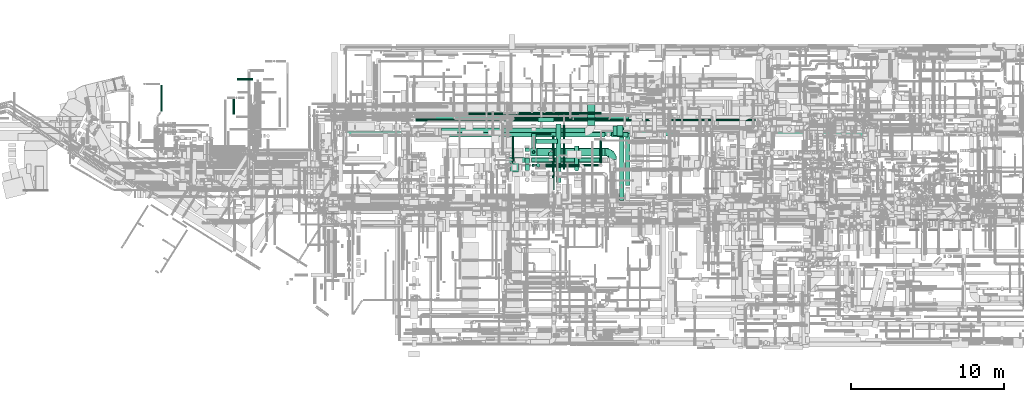
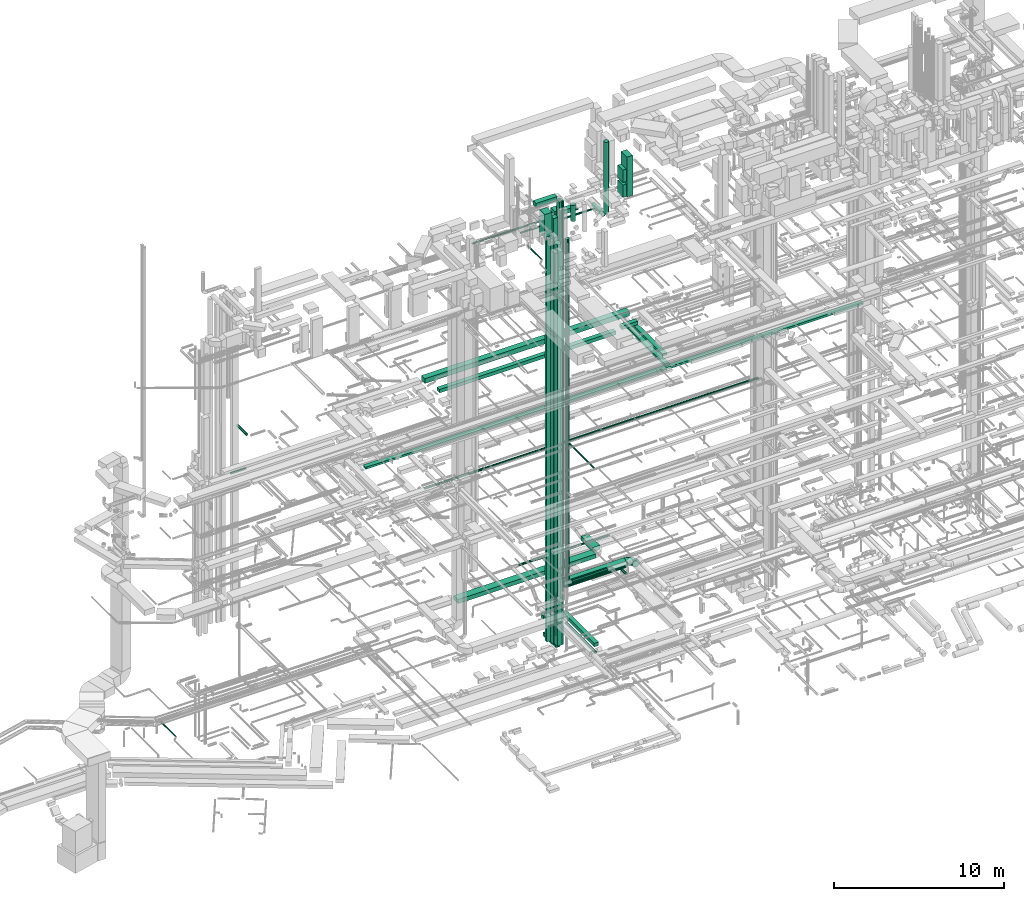
# One storey, part 35 of 337: 46 flow segments, 1 flow fitting.
"""IFC2X3 building model written with IfcOpenShell, lengths in millimetres."""

import ifcopenshell
import ifcopenshell.guid

model = None  # the IFC model being written
_history = None  # IfcOwnerHistory: only IFC2X3 demands one
_inside = {}  # id of a spatial element -> (the spatial element, [elements in it])
_under = {}  # id of a project, library or spatial element -> (it, [spatial elements below it])
_declared = {}  # id of a project -> (the project, [libraries it declares])
_typed = {}  # id of a type object -> (the type object, [elements of that type])
_made_of = {}  # id of a material, layer set ... -> (it, [elements and type objects made of it])


def new_model(schema):
    """Start an empty IFC model of exactly this schema.

    Asked for "IFC4X3", IfcOpenShell would pick the latest addendum, in which some entities
    have other attributes; the version numbers below select the first issue.
    IFC2X3 requires an IfcOwnerHistory on every rooted entity: one is made here for all.
    """
    global model, _history
    if schema == "IFC4X3":
        model = ifcopenshell.file(schema_version=(4, 3, 0, 0))
    else:
        model = ifcopenshell.file(schema=schema)
    _inside.clear()
    _under.clear()
    _declared.clear()
    _typed.clear()
    _made_of.clear()
    _history = None
    if model.schema == "IFC2X3":
        org = make("IfcOrganization", Name="unknown")
        user = make(
            "IfcPersonAndOrganization",
            ThePerson=make("IfcPerson", FamilyName="unknown"),
            TheOrganization=org,
        )
        app = make(
            "IfcApplication",
            ApplicationDeveloper=org,
            Version="unknown",
            ApplicationFullName="unknown",
            ApplicationIdentifier="unknown",
        )
        _history = make(
            "IfcOwnerHistory",
            OwningUser=user,
            OwningApplication=app,
            ChangeAction="ADDED",
            CreationDate=0,
        )
    return model


def make(cls, **values):
    """One entity of the class cls with the attributes given. An attribute that is None is left unset."""
    return model.create_entity(
        cls, **{name: value for name, value in values.items() if value is not None}
    )


def entity(cls, *values):
    """Any entity or typed value of the class cls, its attributes in the order of the schema. None: left unset."""
    e = model.create_entity(cls)
    for i, value in enumerate(values):
        if value is not None:
            e[i] = value
    return e


def rooted(cls, **values):
    """An entity with a GlobalId (a new one), such as an element, a storey or a relation."""
    return make(cls, GlobalId=ifcopenshell.guid.new(), OwnerHistory=_history, **values)


def si_unit(unit_type, name, prefix=None):
    """IfcSIUnit, for example si_unit("LENGTHUNIT", "METRE", prefix="MILLI")."""
    return make("IfcSIUnit", UnitType=unit_type, Prefix=prefix, Name=name)


def converted_unit(unit_type, name, factor, base, dimensions=None, offset=None):
    """IfcConversionBasedUnit, such as the inch: factor (a typed value) times the base unit."""
    return make(
        "IfcConversionBasedUnit"
        if offset is None
        else "IfcConversionBasedUnitWithOffset",
        ConversionOffset=offset,
        Dimensions=None
        if dimensions is None
        else entity("IfcDimensionalExponents", *dimensions),
        UnitType=unit_type,
        Name=name,
        ConversionFactor=make(
            "IfcMeasureWithUnit", ValueComponent=factor, UnitComponent=base
        ),
    )


def derived_unit(unit_type, elements):
    """IfcDerivedUnit: a product of units, each with its exponent."""
    return make(
        "IfcDerivedUnit",
        Elements=[
            make("IfcDerivedUnitElement", Unit=unit, Exponent=power)
            for unit, power in elements
        ],
        UnitType=unit_type,
    )


def assignment(units):
    """IfcUnitAssignment: the units of a project."""
    return None if units is None else make("IfcUnitAssignment", Units=units)


def point(xyz):
    """IfcCartesianPoint."""
    return None if xyz is None else make("IfcCartesianPoint", Coordinates=xyz)


def direction(xyz):
    """IfcDirection."""
    return None if xyz is None else make("IfcDirection", DirectionRatios=xyz)


def frame(location, z_axis=None, x_axis=None):
    """IfcAxis2Placement3D, a coordinate frame: its origin and axes. An axis left out is left unset."""
    return make(
        "IfcAxis2Placement3D",
        Location=point(location),
        Axis=direction(z_axis),
        RefDirection=direction(x_axis),
    )


def frame_2d(location, x_axis=None):
    """IfcAxis2Placement2D, a coordinate frame in the plane: its origin and x axis."""
    return make(
        "IfcAxis2Placement2D", Location=point(location), RefDirection=direction(x_axis)
    )


def origin():
    """The frame at (0, 0, 0) with its axes left unset."""
    return frame((0.0, 0.0, 0.0))


def origin_2d_with_axis():
    """The frame at (0, 0) in the plane with the x axis (1, 0) written out."""
    return frame_2d((0.0, 0.0), x_axis=(1.0, 0.0))


def place(relative_to, where):
    """IfcLocalPlacement: puts the frame where relative to a parent placement (None: the world)."""
    return make(
        "IfcLocalPlacement", PlacementRelTo=relative_to, RelativePlacement=where
    )


def context(
    kind, dimensions, precision=None, world=None, true_north=None, identifier=None
):
    """IfcGeometricRepresentationContext, for example the 3D "Model" context."""
    return make(
        "IfcGeometricRepresentationContext",
        ContextIdentifier=identifier,
        ContextType=kind,
        CoordinateSpaceDimension=dimensions,
        Precision=precision,
        WorldCoordinateSystem=world,
        TrueNorth=true_north,
    )


def subcontext(parent, identifier, kind, view, scale=None):
    """IfcGeometricRepresentationSubContext, for example "Body" below "Model"."""
    return make(
        "IfcGeometricRepresentationSubContext",
        ContextIdentifier=identifier,
        ContextType=kind,
        ParentContext=parent,
        TargetScale=scale,
        TargetView=view,
    )


def project(units=None, contexts=None):
    """IfcProject with its units and contexts."""
    return rooted(
        "IfcProject",
        Name="project",
        RepresentationContexts=contexts,
        UnitsInContext=assignment(units),
    )


def spatial(cls, under=None, at=None, **own):
    """A site, building, storey or space (cls), placed at a placement, below another one or the project."""
    s = rooted(cls, ObjectPlacement=at, **own)
    if under is not None:
        _under.setdefault(under.id(), (under, []))[1].append(s)
    return s


def profile(cls, at=None, kind="AREA", **sizes):
    """A parametric profile (cls). Its sizes go by their IFC names, for example OverallWidth=200.0."""
    return make(cls, ProfileType=kind, Position=at, **sizes)


def rectangle(**sizes):
    """IfcRectangleProfileDef."""
    return profile("IfcRectangleProfileDef", **sizes)


def circle(**sizes):
    """IfcCircleProfileDef."""
    return profile("IfcCircleProfileDef", **sizes)


def extrude(swept, where, along, depth):
    """IfcExtrudedAreaSolid: the profile swept, set in the frame where, extruded along a direction by depth."""
    return make(
        "IfcExtrudedAreaSolid",
        SweptArea=swept,
        Position=where,
        ExtrudedDirection=direction(along),
        Depth=depth,
    )


def faces_of(points, faces, orient=None, outer=None):
    """IfcFace entities. A face is a list of loops; a loop is a list of indices into points, from 0.

    orient and outer hold one flag for each loop. By default every Orientation is true, the
    first loop of a face is its IfcFaceOuterBound and the others are IfcFaceBound.
    """
    made = []
    for i, loops in enumerate(faces):
        bounds = []
        for j, loop in enumerate(loops):
            is_outer = j == 0 if outer is None else outer[i][j]
            bounds.append(
                make(
                    "IfcFaceOuterBound" if is_outer else "IfcFaceBound",
                    Bound=make("IfcPolyLoop", Polygon=[points[k] for k in loop]),
                    Orientation=True if orient is None else orient[i][j],
                )
            )
        made.append(make("IfcFace", Bounds=bounds))
    return made


def faceted_brep(points, faces, orient=None, outer=None, voids=None):
    """IfcFacetedBrep: a solid bounded by flat faces; with voids (closed shells), ...WithVoids."""
    shared = [point(p) for p in points]
    hull = make("IfcClosedShell", CfsFaces=faces_of(shared, faces, orient, outer))
    if voids is None:
        return make("IfcFacetedBrep", Outer=hull)
    return make(
        "IfcFacetedBrepWithVoids",
        Outer=hull,
        Voids=[
            make(cls, CfsFaces=faces_of(shared, fs, o, b)) for cls, fs, o, b in voids
        ],
    )


def shape(context_of_items, identifier, shape_type, items):
    """IfcShapeRepresentation: the items that make up one representation, for example the "Body"."""
    return make(
        "IfcShapeRepresentation",
        ContextOfItems=context_of_items,
        RepresentationIdentifier=identifier,
        RepresentationType=shape_type,
        Items=items,
    )


def source(mapping_origin, context_of_items, identifier, shape_type, items):
    """IfcRepresentationMap: a shape defined once, which mapped items show again and again."""
    return make(
        "IfcRepresentationMap",
        MappingOrigin=mapping_origin,
        MappedRepresentation=shape(context_of_items, identifier, shape_type, items),
    )


def transform(
    local_origin,
    x_axis=None,
    y_axis=None,
    z_axis=None,
    scale=None,
    scale2=None,
    scale3=None,
    uniform=True,
):
    """IfcCartesianTransformationOperator3D, or its non-uniform kind. x_axis, y_axis, z_axis: its Axis1, 2, 3."""
    if uniform:
        return make(
            "IfcCartesianTransformationOperator3D",
            Axis1=direction(x_axis),
            Axis2=direction(y_axis),
            LocalOrigin=point(local_origin),
            Scale=scale,
            Axis3=direction(z_axis),
        )
    return make(
        "IfcCartesianTransformationOperator3DnonUniform",
        Axis1=direction(x_axis),
        Axis2=direction(y_axis),
        LocalOrigin=point(local_origin),
        Scale=scale,
        Axis3=direction(z_axis),
        Scale2=scale2,
        Scale3=scale3,
    )


def mapped(mapping_source, mapping_target):
    """IfcMappedItem: shows the shape of a source again, moved by a transform."""
    return make(
        "IfcMappedItem", MappingSource=mapping_source, MappingTarget=mapping_target
    )


def material(Name=None, Category=None):
    """IfcMaterial."""
    return make("IfcMaterial", Name=Name, Category=Category)


def made_of(thing, what):
    """Note that an element or type object is made of a material, layer set ...; save() writes the relation."""
    if what is not None:
        _made_of.setdefault(what.id(), (what, []))[1].append(thing)
    return thing


def type_object(cls, material=None, **own):
    """A type object (cls), such as IfcWallType, which elements share."""
    return made_of(rooted(cls, **own), material)


def type_shapes(of_type, sources):
    """Give a type object the sources (RepresentationMaps) that its elements show as mapped items."""
    of_type.RepresentationMaps = sources


def element(
    cls,
    number,
    at=None,
    inside=None,
    cuts=None,
    type_object=None,
    material=None,
    context=None,
    identifier="Body",
    shape_type=None,
    held_by="IfcProductDefinitionShape",
    body=None,
    shapes=None,
    **own,
):
    """One element of the class cls, such as IfcWall. Its Tag is "e" and its number.

    at: its placement. inside: the storey or other place that contains it. cuts: it is an
    opening in that element (IfcRelVoidsElement). A single representation is given by context,
    identifier, shape_type and body (its items); several are given by shapes. held_by: the class
    of the entity that holds the representations. save() writes the other relations.
    """
    e = rooted(cls, Tag="e%d" % number, ObjectPlacement=at, **own)
    if body is not None:
        shapes = [shape(context, identifier, shape_type, body)]
    if shapes is not None:
        e.Representation = make(held_by, Representations=shapes)
    if inside is not None:
        _inside.setdefault(inside.id(), (inside, []))[1].append(e)
    if cuts is not None:
        rooted(
            "IfcRelVoidsElement", RelatingBuildingElement=cuts, RelatedOpeningElement=e
        )
    if type_object is not None:
        _typed.setdefault(type_object.id(), (type_object, []))[1].append(e)
    return made_of(e, material)


def aggregate(whole, parts):
    """IfcRelAggregates: a whole, such as a stair, and the parts it consists of."""
    return rooted("IfcRelAggregates", RelatingObject=whole, RelatedObjects=parts)


def save(model, path):
    """Write the relations noted so far, then the file.

    IfcRelAggregates (storeys below a building ...), IfcRelContainedInSpatialStructure (elements
    in a storey), IfcRelDefinesByType, IfcRelAssociatesMaterial and IfcRelDeclares: one each for
    every whole, place, type object, material and project.
    """
    for whole, parts in _under.values():
        aggregate(whole, parts)
    for where, things in _inside.values():
        rooted(
            "IfcRelContainedInSpatialStructure",
            RelatedElements=things,
            RelatingStructure=where,
        )
    for kind, things in _typed.values():
        rooted("IfcRelDefinesByType", RelatedObjects=things, RelatingType=kind)
    for what, things in _made_of.values():
        rooted("IfcRelAssociatesMaterial", RelatedObjects=things, RelatingMaterial=what)
    for by, libraries in _declared.values():
        rooted("IfcRelDeclares", RelatingContext=by, RelatedDefinitions=libraries)
    model.write(path)


model = new_model("IFC2X3")

# Units and contexts
model_context = context("Model", 3, precision=0.01, world=origin(), true_north=direction((6.12303176911189e-17, 1.0)))
body_context = subcontext(model_context, "Body", "Model", "MODEL_VIEW")
ifc_project = project(units=[si_unit("LENGTHUNIT", "METRE", prefix="MILLI"), si_unit("AREAUNIT", "SQUARE_METRE"), si_unit("VOLUMEUNIT", "CUBIC_METRE"), converted_unit("PLANEANGLEUNIT", "DEGREE", entity("IfcRatioMeasure", 0.0174532925199433), si_unit("PLANEANGLEUNIT", "RADIAN"), dimensions=[0, 0, 0, 0, 0, 0, 0]), si_unit("MASSUNIT", "GRAM", prefix="KILO"), derived_unit("MASSDENSITYUNIT", [(si_unit("MASSUNIT", "GRAM", prefix="KILO"), 1), (si_unit("LENGTHUNIT", "METRE"), -3)]), derived_unit("MOMENTOFINERTIAUNIT", [(si_unit("LENGTHUNIT", "METRE"), 4)]), si_unit("TIMEUNIT", "SECOND"), si_unit("FREQUENCYUNIT", "HERTZ"), si_unit("THERMODYNAMICTEMPERATUREUNIT", "DEGREE_CELSIUS"), derived_unit("THERMALTRANSMITTANCEUNIT", [(si_unit("MASSUNIT", "GRAM", prefix="KILO"), 1), (si_unit("THERMODYNAMICTEMPERATUREUNIT", "KELVIN"), -1), (si_unit("TIMEUNIT", "SECOND"), -3)]), derived_unit("VOLUMETRICFLOWRATEUNIT", [(si_unit("LENGTHUNIT", "METRE"), 3), (si_unit("TIMEUNIT", "SECOND"), -1)]), derived_unit("MASSFLOWRATEUNIT", [(si_unit("MASSUNIT", "GRAM", prefix="KILO"), 1), (si_unit("TIMEUNIT", "SECOND"), -1)]), derived_unit("ROTATIONALFREQUENCYUNIT", [(si_unit("TIMEUNIT", "SECOND"), -1)]), si_unit("ELECTRICCURRENTUNIT", "AMPERE"), si_unit("ELECTRICVOLTAGEUNIT", "VOLT"), si_unit("POWERUNIT", "WATT"), si_unit("FORCEUNIT", "NEWTON", prefix="KILO"), si_unit("ILLUMINANCEUNIT", "LUX"), si_unit("LUMINOUSFLUXUNIT", "LUMEN"), si_unit("LUMINOUSINTENSITYUNIT", "CANDELA"), derived_unit("USERDEFINED", [(si_unit("MASSUNIT", "GRAM", prefix="KILO"), -1), (si_unit("LENGTHUNIT", "METRE"), -2), (si_unit("TIMEUNIT", "SECOND"), 3), (si_unit("LUMINOUSFLUXUNIT", "LUMEN"), 1)]), derived_unit("LINEARVELOCITYUNIT", [(si_unit("LENGTHUNIT", "METRE"), 1), (si_unit("TIMEUNIT", "SECOND"), -1)]), si_unit("PRESSUREUNIT", "PASCAL"), derived_unit("USERDEFINED", [(si_unit("LENGTHUNIT", "METRE"), -2), (si_unit("MASSUNIT", "GRAM", prefix="KILO"), 1), (si_unit("TIMEUNIT", "SECOND"), -2)]), derived_unit("LINEARFORCEUNIT", [(si_unit("MASSUNIT", "GRAM", prefix="KILO"), 1), (si_unit("LENGTHUNIT", "METRE"), 1), (si_unit("TIMEUNIT", "SECOND"), -2), (si_unit("LENGTHUNIT", "METRE"), -1)]), derived_unit("PLANARFORCEUNIT", [(si_unit("MASSUNIT", "GRAM", prefix="KILO"), 1), (si_unit("LENGTHUNIT", "METRE"), 1), (si_unit("TIMEUNIT", "SECOND"), -2), (si_unit("LENGTHUNIT", "METRE"), -2)])], contexts=[model_context])

# Site, building, storey
site_placement = place(None, origin())
site = spatial("IfcSite", under=ifc_project, at=site_placement, CompositionType="ELEMENT")
building_placement = place(site_placement, origin())
building = spatial("IfcBuilding", under=site, at=building_placement, CompositionType="ELEMENT")
storey_placement = place(building_placement, origin())
storey = spatial("IfcBuildingStorey", under=building, at=storey_placement, CompositionType="ELEMENT", Elevation=0.0)

# Flow segments
duct_segment_type_1 = type_object("IfcDuctSegmentType", PredefinedType="NOTDEFINED")
flow_segment_1_placement = place(storey_placement, frame((31410.12, 12399.99, -885.0)))
element("IfcFlowSegment", 1, at=flow_segment_1_placement, inside=storey, type_object=duct_segment_type_1, context=body_context, shape_type="SweptSolid", body=[
    extrude(rectangle(XDim=249.999999999999, YDim=300.000000000002, at=origin_2d_with_axis()), frame((150.1, 125.0, 0.0), z_axis=(-2.94447184395279e-05, 0.0, 1.0), x_axis=(0.0, -1.0, 0.0)), (0.0, 0.0, 1.0), 3565.00004936891),
])
flow_segment_2_placement = place(storey_placement, frame((31410.22, 12799.99, -1285.0)))
element("IfcFlowSegment", 2, at=flow_segment_2_placement, inside=storey, type_object=duct_segment_type_1, context=body_context, shape_type="SweptSolid", body=[
    extrude(rectangle(XDim=1470.0000048997, YDim=300.000000000001, at=origin_2d_with_axis()), frame((150.0, 735.0, 0.0), z_axis=(0.0, 0.0, 1.0), x_axis=(-5.17399198813751e-06, 1.0, 0.0)), (0.0, 0.0, 1.0), 250.0),
])
flow_segment_3_placement = place(storey_placement, frame((30990.11, 12314.49, -600.0)))
element("IfcFlowSegment", 3, at=flow_segment_3_placement, inside=storey, type_object=duct_segment_type_1, context=body_context, shape_type="SweptSolid", body=[
    extrude(rectangle(XDim=300.000000000001, YDim=350.000000000001, at=origin_2d_with_axis()), frame((150.0, 175.0, 0.0), z_axis=(0.0, 0.0, 1.0), x_axis=(-1.0, 0.0, 0.0)), (0.0, 0.0, 1.0), 30665.0),
])
flow_segment_4_placement = place(storey_placement, frame((35072.98, 14776.58, 3150.0)))
element("IfcFlowSegment", 4, at=flow_segment_4_placement, inside=storey, type_object=duct_segment_type_1, context=body_context, shape_type="SweptSolid", body=[
    extrude(rectangle(XDim=1372.68213720572, YDim=499.999999999999, at=origin_2d_with_axis()), frame((250.0, 686.34, 0.0), z_axis=(0.0, 0.0, 1.0), x_axis=(0.0, 1.0, 0.0)), (0.0, 0.0, 1.0), 300.0),
])
flow_segment_5_placement = place(storey_placement, frame((23836.83, 15110.0, 19000.0)))
element("IfcFlowSegment", 5, at=flow_segment_5_placement, inside=storey, type_object=duct_segment_type_1, context=body_context, shape_type="SweptSolid", body=[
    extrude(rectangle(XDim=13961.9063506124, YDim=400.0, at=origin_2d_with_axis()), frame((6980.95, 200.0, 0.0), z_axis=(0.0, 0.0, 1.0), x_axis=(-1.0, 0.0, 0.0)), (0.0, 0.0, 1.0), 349.999999999998),
])
flow_segment_6_placement = place(storey_placement, frame((24218.73, 14025.53, 18850.0)))
element("IfcFlowSegment", 6, at=flow_segment_6_placement, inside=storey, type_object=duct_segment_type_1, context=body_context, shape_type="SweptSolid", body=[
    extrude(rectangle(XDim=12012.1825406949, YDim=300.000000000001, at=origin_2d_with_axis()), frame((6006.09, 150.0, 0.0)), (0.0, 0.0, 1.0), 249.999999999999),
])
flow_segment_7_placement = place(storey_placement, frame((37170.11, 9875.09, 18750.0)))
element("IfcFlowSegment", 7, at=flow_segment_7_placement, inside=storey, type_object=duct_segment_type_1, context=body_context, shape_type="SweptSolid", body=[
    extrude(rectangle(XDim=4763.27219075205, YDim=300.000000000001, at=origin_2d_with_axis()), frame((150.0, 2381.64, 0.0), z_axis=(0.0, 0.0, 1.0), x_axis=(0.0, -1.0, 0.0)), (0.0, 0.0, 1.0), 150.000000000001),
])
flow_segment_8_placement = place(storey_placement, frame((36658.73, 14025.53, 19050.0)))
element("IfcFlowSegment", 8, at=flow_segment_8_placement, inside=storey, type_object=duct_segment_type_1, context=body_context, shape_type="SweptSolid", body=[
    extrude(rectangle(XDim=1062.18254069484, YDim=300.000000000001, at=origin_2d_with_axis()), frame((531.09, 150.0, 0.0)), (0.0, 0.0, 1.0), 249.999999999999),
])
flow_segment_9_placement = place(storey_placement, frame((37570.04, 10850.85, 18750.0)))
element("IfcFlowSegment", 9, at=flow_segment_9_placement, inside=storey, type_object=duct_segment_type_1, context=body_context, shape_type="SweptSolid", body=[
    extrude(rectangle(XDim=3409.69550041494, YDim=300.000000000001, at=origin_2d_with_axis()), frame((150.0, 1704.85, 0.0), z_axis=(0.0, 0.0, 1.0), x_axis=(0.0, -1.0, 0.0)), (0.0, 0.0, 1.0), 150.000000000001),
])
flow_segment_10_placement = place(storey_placement, frame((19234.14, 14093.91, 15050.0)))
element("IfcFlowSegment", 10, at=flow_segment_10_placement, inside=storey, type_object=duct_segment_type_1, context=body_context, shape_type="SweptSolid", body=[
    extrude(rectangle(XDim=33896.0508882684, YDim=299.999999999999, at=origin_2d_with_axis()), frame((16948.03, 150.0, 0.0)), (0.0, 0.0, 1.0), 150.000000000001),
])
flow_segment_11_placement = place(storey_placement, frame((31409.27, 12349.99, 2980.0)))
element("IfcFlowSegment", 11, at=flow_segment_11_placement, inside=storey, type_object=duct_segment_type_1, context=body_context, shape_type="SweptSolid", body=[
    extrude(rectangle(XDim=349.999999999998, YDim=300.000000000002, at=origin_2d_with_axis()), frame((150.83, 175.0, 0.0), z_axis=(-2.95494293889361e-05, 0.0, 1.0), x_axis=(0.0, -1.0, 0.0)), (0.0, 0.0, 1.0), 28119.9986991333),
])
flow_segment_12_placement = place(storey_placement, frame((37023.99, 14094.6, 28430.0)))
element("IfcFlowSegment", 12, at=flow_segment_12_placement, inside=storey, type_object=duct_segment_type_1, context=body_context, shape_type="SweptSolid", body=[
    extrude(rectangle(XDim=400.0, YDim=700.000000000001, at=origin_2d_with_axis()), frame((200.0, 350.0, 0.0), z_axis=(0.0, 0.0, 1.0), x_axis=(-1.0, 0.0, 0.0)), (0.0, 0.0, 1.0), 2870.00000000001),
])
flow_segment_13_placement = place(storey_placement, frame((36770.03, 14144.61, 28445.0)))
element("IfcFlowSegment", 13, at=flow_segment_13_placement, inside=storey, type_object=duct_segment_type_1, context=body_context, shape_type="SweptSolid", body=[
    extrude(rectangle(XDim=233.954250839629, YDim=600.0, at=origin_2d_with_axis()), frame((116.98, 300.0, 0.0), z_axis=(0.0, 0.0, 1.0), x_axis=(-1.0, 0.0, 0.0)), (0.0, 0.0, 1.0), 900.000000000003),
])
flow_segment_14_placement = place(storey_placement, frame((36770.03, 14144.61, 29535.0)))
element("IfcFlowSegment", 14, at=flow_segment_14_placement, inside=storey, type_object=duct_segment_type_1, context=body_context, shape_type="SweptSolid", body=[
    extrude(rectangle(XDim=233.954249089629, YDim=600.0, at=origin_2d_with_axis()), frame((116.98, 300.0, 0.0), z_axis=(0.0, 0.0, 1.0), x_axis=(-1.0, 0.0, 0.0)), (0.0, 0.0, 1.0), 900.000000000003),
])
flow_segment_15_placement = place(storey_placement, frame((25528.67, 14126.58, 3150.0)))
element("IfcFlowSegment", 15, at=flow_segment_15_placement, inside=storey, type_object=duct_segment_type_1, context=body_context, shape_type="SweptSolid", body=[
    extrude(rectangle(XDim=9394.31018831892, YDim=499.999999999999, at=origin_2d_with_axis()), frame((4697.16, 250.0, 0.0), z_axis=(0.0, 0.0, 1.0), x_axis=(-1.0, 0.0, 0.0)), (0.0, 0.0, 1.0), 300.0),
])
flow_segment_16_placement = place(storey_placement, frame((31358.92, 12798.57, 2649.96)))
element("IfcFlowSegment", 16, at=flow_segment_16_placement, inside=storey, type_object=duct_segment_type_1, context=body_context, shape_type="SweptSolid", body=[
    extrude(rectangle(XDim=400.000000000001, YDim=499.999999999997, at=frame_2d((0.0, 0.0), x_axis=(0.0, 1.0))), frame((200.0, 250.0, 0.04), z_axis=(0.000204721632259776, 0.0, 0.999999979044526), x_axis=(0.0, -1.0, 0.0)), (0.0, 0.0, 1.0), 27499.9288987028),
])
flow_segment_17_placement = place(storey_placement, frame((30984.29, 11845.06, -450.0)))
element("IfcFlowSegment", 17, at=flow_segment_17_placement, inside=storey, type_object=duct_segment_type_1, context=body_context, shape_type="SweptSolid", body=[
    extrude(rectangle(XDim=300.000000000001, YDim=400.0, at=origin_2d_with_axis()), frame((150.0, 200.0, 0.0), z_axis=(0.0, 0.0, 1.0), x_axis=(-1.0, 0.0, 0.0)), (0.0, 0.0, 1.0), 28900.0),
])
flow_segment_18_placement = place(storey_placement, frame((30984.33, 13099.88, -900.0)))
element("IfcFlowSegment", 18, at=flow_segment_18_placement, inside=storey, type_object=duct_segment_type_1, context=body_context, shape_type="SweptSolid", body=[
    extrude(rectangle(XDim=200.000000000002, YDim=300.000000000001, at=origin_2d_with_axis()), frame((150.0, 100.0, 0.0), z_axis=(0.0, 0.0, 1.0), x_axis=(0.0, 1.0, 0.0)), (0.0, 0.0, 1.0), 30324.7762498852),
])
flow_segment_19_placement = place(storey_placement, frame((33038.7, 11052.57, -725.0)))
element("IfcFlowSegment", 19, at=flow_segment_19_placement, inside=storey, type_object=duct_segment_type_1, context=body_context, shape_type="SweptSolid", body=[
    extrude(rectangle(XDim=3816.61439284741, YDim=300.000000000001, at=origin_2d_with_axis()), frame((150.0, 1908.31, 0.0), z_axis=(0.0, 0.0, 1.0), x_axis=(0.0, -1.0, 0.0)), (0.0, 0.0, 1.0), 250.0),
])
flow_segment_20_placement = place(storey_placement, frame((31860.22, 15019.18, -725.0)))
element("IfcFlowSegment", 20, at=flow_segment_20_placement, inside=storey, type_object=duct_segment_type_1, context=body_context, shape_type="SweptSolid", body=[
    extrude(rectangle(XDim=1028.47903642511, YDim=299.999999999999, at=origin_2d_with_axis()), frame((514.24, 150.0, 0.0), z_axis=(0.0, 0.0, 1.0), x_axis=(-1.0, 0.0, 0.0)), (0.0, 0.0, 1.0), 250.0),
])
flow_segment_21_placement = place(storey_placement, frame((29824.08, 12349.99, 31250.0)))
element("IfcFlowSegment", 21, at=flow_segment_21_placement, inside=storey, type_object=duct_segment_type_1, context=body_context, shape_type="SweptSolid", body=[
    extrude(rectangle(XDim=1435.1898383749, YDim=350.000000000001, at=origin_2d_with_axis()), frame((717.59, 175.0, 0.0), z_axis=(0.0, 0.0, 1.0), x_axis=(-1.0, 0.0, 0.0)), (0.0, 0.0, 1.0), 300.000000000001),
])
duct_segment_type_2 = type_object("IfcDuctSegmentType", PredefinedType="NOTDEFINED")
flow_segment_22_placement = place(storey_placement, frame((31477.32, 12966.97, -590.0)))
element("IfcFlowSegment", 22, at=flow_segment_22_placement, inside=storey, type_object=duct_segment_type_2, context=body_context, shape_type="SweptSolid", body=[
    extrude(circle(Radius=80.0, at=origin_2d_with_axis()), frame((81.6, 81.6, 0.0)), (0.0, 0.0, 1.0), 3040.00000000001),
])
flow_segment_23_placement = place(storey_placement, frame((31718.92, 14176.83, -831.6)))
element("IfcFlowSegment", 23, at=flow_segment_23_placement, inside=storey, type_object=duct_segment_type_2, context=body_context, shape_type="SweptSolid", body=[
    extrude(circle(Radius=80.0, at=origin_2d_with_axis()), frame((0.0, 81.6, 81.6), z_axis=(1.0, 0.0, 0.0), x_axis=(0.0, -1.0, 0.0)), (0.0, 0.0, 1.0), 975.558190000004),
])
flow_segment_24_placement = place(storey_placement, frame((7167.36, 15709.94, -1001.6)))
element("IfcFlowSegment", 24, at=flow_segment_24_placement, inside=storey, type_object=duct_segment_type_2, context=body_context, shape_type="SweptSolid", body=[
    extrude(circle(Radius=50.0, at=origin_2d_with_axis()), frame((51.6, 0.0, 51.6), z_axis=(0.0, 1.0, 0.0), x_axis=(1.0, 0.0, 0.0)), (0.0, 0.0, 1.0), 1699.40204376272),
])
flow_segment_25_placement = place(storey_placement, frame((31730.09, 12365.89, 3140.9)))
element("IfcFlowSegment", 25, at=flow_segment_25_placement, inside=storey, type_object=duct_segment_type_2, context=body_context, shape_type="SweptSolid", body=[
    extrude(circle(Radius=157.5, at=origin_2d_with_axis()), frame((0.0, 159.1, 159.1), z_axis=(1.0, 0.0, 0.0), x_axis=(0.0, 1.0, 0.0)), (0.0, 0.0, 1.0), 4313.00282220616),
])
flow_segment_26_placement = place(storey_placement, frame((31779.06, 12796.97, 2828.4)))
element("IfcFlowSegment", 26, at=flow_segment_26_placement, inside=storey, type_object=duct_segment_type_2, context=body_context, shape_type="SweptSolid", body=[
    extrude(circle(Radius=250.0, at=origin_2d_with_axis()), frame((0.0, 251.6, 251.6), z_axis=(1.0, 0.0, 0.0), x_axis=(0.0, -1.0, 0.0)), (0.0, 0.0, 1.0), 4465.50299374622),
])
flow_segment_27_placement = place(storey_placement, frame((23824.32, 15056.69, 11368.4)))
element("IfcFlowSegment", 27, at=flow_segment_27_placement, inside=storey, type_object=duct_segment_type_2, context=body_context, shape_type="SweptSolid", body=[
    extrude(circle(Radius=80.0, at=origin_2d_with_axis()), frame((0.0, 81.6, 81.6), z_axis=(1.0, 0.0, 0.0), x_axis=(0.0, 1.0, 0.0)), (0.0, 0.0, 1.0), 22736.2858300203),
])
flow_segment_28_placement = place(storey_placement, frame((33494.61, 11923.74, 11398.4)))
element("IfcFlowSegment", 28, at=flow_segment_28_placement, inside=storey, type_object=duct_segment_type_2, context=body_context, shape_type="SweptSolid", body=[
    extrude(circle(Radius=50.0, at=origin_2d_with_axis()), frame((51.6, 0.0, 51.6), z_axis=(0.0, 1.0, 0.0), x_axis=(-1.0, 0.0, 0.0)), (0.0, 0.0, 1.0), 2911.10395736614),
])
flow_segment_29_placement = place(storey_placement, frame((30296.25, 15143.34, 3518.4)))
element("IfcFlowSegment", 29, at=flow_segment_29_placement, inside=storey, type_object=duct_segment_type_2, context=body_context, shape_type="SweptSolid", body=[
    extrude(circle(Radius=80.0, at=origin_2d_with_axis()), frame((0.0, 81.6, 81.6), z_axis=(1.0, 0.0, 0.0), x_axis=(0.0, -1.0, 0.0)), (0.0, 0.0, 1.0), 3824.99999999995),
])
flow_segment_30_placement = place(storey_placement, frame((34181.25, 15173.34, 3548.4)))
element("IfcFlowSegment", 30, at=flow_segment_30_placement, inside=storey, type_object=duct_segment_type_2, context=body_context, shape_type="SweptSolid", body=[
    extrude(circle(Radius=50.0, at=origin_2d_with_axis()), frame((0.0, 51.6, 51.6), z_axis=(1.0, 0.0, 0.0), x_axis=(0.0, 1.0, 0.0)), (0.0, 0.0, 1.0), 2280.00000000001),
])
flow_segment_31_placement = place(storey_placement, frame((12159.4, 17717.24, 14918.4)))
element("IfcFlowSegment", 31, at=flow_segment_31_placement, inside=storey, type_object=duct_segment_type_2, context=body_context, shape_type="SweptSolid", body=[
    extrude(circle(Radius=80.0, at=origin_2d_with_axis()), frame((0.0, 81.6, 81.6), z_axis=(1.0, 0.0, 0.0), x_axis=(0.0, -1.0, 0.0)), (0.0, 0.0, 1.0), 1040.00000000004),
])
flow_segment_32_placement = place(storey_placement, frame((31697.12, 12097.06, 3318.4)))
element("IfcFlowSegment", 32, at=flow_segment_32_placement, inside=storey, type_object=duct_segment_type_2, context=body_context, shape_type="SweptSolid", body=[
    extrude(circle(Radius=80.0, at=origin_2d_with_axis()), frame((0.0, 81.6, 81.6), z_axis=(1.0, 0.0, 0.0), x_axis=(0.0, 1.0, 0.0)), (0.0, 0.0, 1.0), 4108.95923899879),
])
flow_segment_33_placement = place(storey_placement, frame((35884.48, 12338.65, 2638.4)))
element("IfcFlowSegment", 33, at=flow_segment_33_placement, inside=storey, type_object=duct_segment_type_2, context=body_context, shape_type="SweptSolid", body=[
    extrude(circle(Radius=80.0, at=origin_2d_with_axis()), frame((81.6, 0.0, 81.6), z_axis=(0.0, 1.0, 0.0), x_axis=(1.0, 0.0, 0.0)), (0.0, 0.0, 1.0), 1557.50000000001),
])
flow_segment_34_placement = place(storey_placement, frame((31455.52, 12097.06, 3560.0)))
element("IfcFlowSegment", 34, at=flow_segment_34_placement, inside=storey, type_object=duct_segment_type_2, context=body_context, shape_type="SweptSolid", body=[
    extrude(circle(Radius=80.0, at=origin_2d_with_axis()), frame((81.6, 81.6, 0.0), z_axis=(0.0, 0.0, 1.0), x_axis=(0.0, -1.0, 0.0)), (0.0, 0.0, 1.0), 27685.0691209106),
])
flow_segment_35_placement = place(storey_placement, frame((11870.62, 15504.81, 19168.4)))
element("IfcFlowSegment", 35, at=flow_segment_35_placement, inside=storey, type_object=duct_segment_type_2, context=body_context, shape_type="SweptSolid", body=[
    extrude(circle(Radius=80.0, at=origin_2d_with_axis()), frame((81.6, 0.0, 81.6), z_axis=(0.0, 1.0, 0.0), x_axis=(1.0, 0.0, 0.0)), (0.0, 0.0, 1.0), 1116.25),
])
flow_segment_36_placement = place(storey_placement, frame((30148.1, 12340.68, 27348.4)))
element("IfcFlowSegment", 36, at=flow_segment_36_placement, inside=storey, type_object=duct_segment_type_2, context=body_context, shape_type="SweptSolid", body=[
    extrude(circle(Radius=50.0, at=origin_2d_with_axis()), frame((51.6, 0.0, 51.6), z_axis=(0.0, 1.0, 0.0), x_axis=(-1.0, 0.0, 0.0)), (0.0, 0.0, 1.0), 1714.27864376271),
])
flow_segment_37_placement = place(storey_placement, frame((27318.22, 15485.93, 27535.9)))
element("IfcFlowSegment", 37, at=flow_segment_37_placement, inside=storey, type_object=duct_segment_type_2, context=body_context, shape_type="SweptSolid", body=[
    extrude(circle(Radius=62.5, at=origin_2d_with_axis()), frame((0.0, 64.1, 64.1), z_axis=(1.0, 0.0, 0.0), x_axis=(0.0, -1.0, 0.0)), (0.0, 0.0, 1.0), 7204.99999999999),
])
flow_segment_38_placement = place(storey_placement, frame((30615.2, 15517.89, 27135.9)))
element("IfcFlowSegment", 38, at=flow_segment_38_placement, inside=storey, type_object=duct_segment_type_2, context=body_context, shape_type="SweptSolid", body=[
    extrude(circle(Radius=62.5, at=origin_2d_with_axis()), frame((0.0, 64.1, 64.1), z_axis=(1.0, 0.0, 0.0), x_axis=(0.0, -1.0, 0.0)), (0.0, 0.0, 1.0), 5367.84823147997),
])
flow_segment_39_placement = place(storey_placement, frame((32107.99, 12052.06, 3523.4)))
element("IfcFlowSegment", 39, at=flow_segment_39_placement, inside=storey, type_object=duct_segment_type_2, context=body_context, shape_type="SweptSolid", body=[
    extrude(circle(Radius=125.0, at=origin_2d_with_axis()), frame((0.0, 126.6, 126.6), z_axis=(1.0, 0.0, 0.0), x_axis=(0.0, 1.0, 0.0)), (0.0, 0.0, 1.0), 2462.42191419359),
])
flow_segment_40_placement = place(storey_placement, frame((31731.4, 12052.06, 3900.0)))
element("IfcFlowSegment", 40, at=flow_segment_40_placement, inside=storey, type_object=duct_segment_type_2, context=body_context, shape_type="SweptSolid", body=[
    extrude(circle(Radius=125.0, at=origin_2d_with_axis()), frame((126.6, 126.6, 0.0), z_axis=(0.0, 0.0, 1.0), x_axis=(0.0, -1.0, 0.0)), (0.0, 0.0, 1.0), 24550.0),
])
flow_segment_41_placement = place(storey_placement, frame((32772.88, 10562.12, -831.6)))
element("IfcFlowSegment", 41, at=flow_segment_41_placement, inside=storey, type_object=duct_segment_type_2, context=body_context, shape_type="SweptSolid", body=[
    extrude(circle(Radius=80.0, at=origin_2d_with_axis()), frame((81.6, 0.0, 81.6), z_axis=(0.0, 1.0, 0.0), x_axis=(-1.0, 0.0, 0.0)), (0.0, 0.0, 1.0), 3536.31231002031),
])
duct_segment_type_3 = type_object("IfcDuctSegmentType", PredefinedType="NOTDEFINED")
flow_segment_42_placement = place(storey_placement, frame((34221.18, 12249.59, 29093.18)))
element("IfcFlowSegment", 42, at=flow_segment_42_placement, inside=storey, type_object=duct_segment_type_3, context=body_context, shape_type="SweptSolid", body=[
    extrude(circle(Radius=150.0, at=origin_2d_with_axis()), frame((151.6, 0.0, 151.6), z_axis=(0.0, 1.0, 0.0), x_axis=(-1.0, 0.0, 0.0)), (0.0, 0.0, 1.0), 1200.00000000002),
])
flow_segment_43_placement = place(storey_placement, frame((34221.18, 11798.0, 29544.78)))
element("IfcFlowSegment", 43, at=flow_segment_43_placement, inside=storey, type_object=duct_segment_type_3, context=body_context, shape_type="SweptSolid", body=[
    extrude(circle(Radius=150.0, at=origin_2d_with_axis()), frame((151.6, 151.6, 0.0), z_axis=(0.0, 0.0, 1.0), x_axis=(-1.0, 0.0, 0.0)), (0.0, 0.0, 1.0), 5160.00000000001),
])
flow_segment_44_placement = place(storey_placement, frame((32529.23, 12772.5, 29000.0)))
element("IfcFlowSegment", 44, at=flow_segment_44_placement, inside=storey, type_object=duct_segment_type_3, context=body_context, shape_type="SweptSolid", body=[
    extrude(circle(Radius=150.0, at=origin_2d_with_axis()), frame((151.6, 151.6, 0.0)), (-1.33694300075149e-09, 0.0, 1.0), 1164.77624531604),
])
duct_segment_type_4 = type_object("IfcDuctSegmentType", PredefinedType="NOTDEFINED")
flow_segment_45_placement = place(storey_placement, frame((31434.49, 13599.59, 29094.78)))
element("IfcFlowSegment", 45, at=flow_segment_45_placement, inside=storey, type_object=duct_segment_type_4, context=body_context, shape_type="SweptSolid", body=[
    extrude(rectangle(XDim=1674.53386203267, YDim=300.000000000001, at=origin_2d_with_axis()), frame((837.27, 150.0, 0.0)), (0.0, 0.0, 1.0), 300.000000000001),
])
flow_segment_46_placement = place(storey_placement, frame((30065.03, 11745.06, 29390.0)))
element("IfcFlowSegment", 46, at=flow_segment_46_placement, inside=storey, type_object=duct_segment_type_4, context=body_context, shape_type="SweptSolid", body=[
    extrude(rectangle(XDim=499.999999999999, YDim=600.0, at=origin_2d_with_axis()), frame((250.0, 300.0, 0.0), z_axis=(0.0, 0.0, 1.0), x_axis=(-1.0, 0.0, 0.0)), (0.0, 0.0, 1.0), 1640.0),
])

# Flow fitting
ifc_material = material()
duct_fitting_type = type_object("IfcDuctFittingType", PredefinedType="NOTDEFINED", material=ifc_material)
shared_shape = source(origin(), body_context, "Body", "Brep", [
    faceted_brep([(-500.0, 0.0, -250.0), (-500.0, -55.63, -243.73), (-500.0, -108.47, -225.24), (-500.0, -155.87, -195.46), (-500.0, -195.46, -155.87), (-500.0, -225.24, -108.47), (-500.0, -243.73, -55.63), (-500.0, -250.0, 0.0), (-500.0, -243.73, 55.63), (-500.0, -225.24, 108.47), (-500.0, -195.46, 155.87), (-500.0, -155.87, 195.46), (-500.0, -108.47, 225.24), (-500.0, -55.63, 243.73), (-500.0, 0.0, 250.0), (-500.0, 55.63, 243.73), (-500.0, 108.47, 225.24), (-500.0, 155.87, 195.46), (-500.0, 195.46, 155.87), (-500.0, 225.24, 108.47), (-500.0, 243.73, 55.63), (-500.0, 250.0, 0.0), (-500.0, 243.73, -55.63), (-500.0, 225.24, -108.47), (-500.0, 195.46, -155.87), (-500.0, 155.87, -195.46), (-500.0, 108.47, -225.24), (-500.0, 55.63, -243.73), (-366.03, 0.0, 250.0), (-379.09, 48.77, 245.2), (-391.66, 95.67, 230.97), (-403.24, 138.89, 207.87), (-413.39, 176.78, 176.78), (-421.72, 207.87, 138.89), (-427.91, 230.97, 95.67), (-431.73, 245.2, 48.77), (-433.01, 250.0, 0.0), (-431.73, 245.2, -48.77), (-427.91, 230.97, -95.67), (-421.72, 207.87, -138.89), (-413.39, 176.78, -176.78), (-403.24, 138.89, -207.87), (-391.66, 95.67, -230.97), (-379.09, 48.77, -245.2), (-366.03, 0.0, -250.0), (-352.96, -48.77, -245.2), (-340.39, -95.67, -230.97), (-328.81, -138.89, -207.87), (-318.66, -176.78, -176.78), (-310.33, -207.87, -138.89), (-304.14, -230.97, -95.67), (-300.33, -245.2, -48.77), (-299.04, -250.0, 0.0), (-300.33, -245.2, 48.77), (-304.14, -230.97, 95.67), (-310.33, -207.87, 138.89), (-318.66, -176.78, 176.78), (-328.81, -138.89, 207.87), (-340.39, -95.67, 230.97), (-352.96, -48.77, 245.2), (-133.97, 133.97, 250.0), (-169.68, 169.68, 245.2), (-204.01, 204.01, 230.97), (-235.65, 235.65, 207.87), (-263.38, 263.38, 176.78), (-286.14, 286.14, 138.89), (-303.06, 303.06, 95.67), (-313.47, 313.47, 48.77), (-316.99, 316.99, 0.0), (-313.47, 313.47, -48.77), (-303.06, 303.06, -95.67), (-286.14, 286.14, -138.89), (-263.38, 263.38, -176.78), (-235.65, 235.65, -207.87), (-204.01, 204.01, -230.97), (-169.68, 169.68, -245.2), (-133.97, 133.97, -250.0), (-98.27, 98.27, -245.2), (-63.94, 63.94, -230.97), (-32.3, 32.3, -207.87), (-4.57, 4.57, -176.78), (18.19, -18.19, -138.89), (35.11, -35.11, -95.67), (45.52, -45.52, -48.77), (49.04, -49.04, 0.0), (45.52, -45.52, 48.77), (35.11, -35.11, 95.67), (18.19, -18.19, 138.89), (-4.57, 4.57, 176.78), (-32.3, 32.3, 207.87), (-63.94, 63.94, 230.97), (-98.27, 98.27, 245.2), (0.0, 366.03, 250.0), (-48.77, 379.09, 245.2), (-95.67, 391.66, 230.97), (-138.89, 403.24, 207.87), (-176.78, 413.39, 176.78), (-207.87, 421.72, 138.89), (-230.97, 427.91, 95.67), (-245.2, 431.73, 48.77), (-250.0, 433.01, 0.0), (-245.2, 431.73, -48.77), (-230.97, 427.91, -95.67), (-207.87, 421.72, -138.89), (-176.78, 413.39, -176.78), (-138.89, 403.24, -207.87), (-95.67, 391.66, -230.97), (-48.77, 379.09, -245.2), (0.0, 366.03, -250.0), (48.77, 352.96, -245.2), (95.67, 340.39, -230.97), (138.89, 328.81, -207.87), (176.78, 318.66, -176.78), (207.87, 310.33, -138.89), (230.97, 304.14, -95.67), (245.2, 300.33, -48.77), (250.0, 299.04, 0.0), (245.2, 300.33, 48.77), (230.97, 304.14, 95.67), (207.87, 310.33, 138.89), (176.78, 318.66, 176.78), (138.89, 328.81, 207.87), (95.67, 340.39, 230.97), (48.77, 352.96, 245.2), (0.0, 500.0, -250.0), (-55.63, 500.0, -243.73), (-108.47, 500.0, -225.24), (-155.87, 500.0, -195.46), (-195.46, 500.0, -155.87), (-225.24, 500.0, -108.47), (-243.73, 500.0, -55.63), (-250.0, 500.0, 0.0), (-243.73, 500.0, 55.63), (-225.24, 500.0, 108.47), (-195.46, 500.0, 155.87), (-155.87, 500.0, 195.46), (-108.47, 500.0, 225.24), (-55.63, 500.0, 243.73), (0.0, 500.0, 250.0), (55.63, 500.0, 243.73), (108.47, 500.0, 225.24), (155.87, 500.0, 195.46), (195.46, 500.0, 155.87), (225.24, 500.0, 108.47), (243.73, 500.0, 55.63), (250.0, 500.0, 0.0), (243.73, 500.0, -55.63), (225.24, 500.0, -108.47), (195.46, 500.0, -155.87), (155.87, 500.0, -195.46), (108.47, 500.0, -225.24), (55.63, 500.0, -243.73)], [[[0, 1, 2, 3, 4, 5, 6, 7, 8, 9, 10, 11, 12, 13, 14, 15, 16, 17, 18, 19, 20, 21, 22, 23, 24, 25, 26, 27]], [[28, 29, 14]], [[30, 31, 16]], [[29, 30, 15]], [[14, 29, 15]], [[15, 30, 16]], [[31, 17, 16]], [[31, 32, 17]], [[32, 33, 18]], [[34, 35, 20]], [[33, 34, 19]], [[18, 33, 19]], [[35, 21, 20]], [[20, 19, 34]], [[21, 35, 36]], [[32, 18, 17]], [[36, 37, 21]], [[38, 39, 23]], [[37, 38, 22]], [[21, 37, 22]], [[24, 23, 39]], [[38, 23, 22]], [[39, 40, 24]], [[41, 42, 26]], [[43, 44, 0]], [[42, 43, 27]], [[40, 25, 24]], [[40, 41, 25]], [[26, 25, 41]], [[42, 27, 26]], [[43, 0, 27]], [[1, 44, 45]], [[45, 46, 1]], [[47, 2, 46]], [[0, 44, 1]], [[1, 46, 2]], [[47, 3, 2]], [[47, 48, 3]], [[5, 49, 50]], [[50, 51, 6]], [[52, 7, 51]], [[48, 4, 3]], [[48, 49, 4]], [[5, 4, 49]], [[50, 6, 5]], [[51, 7, 6]], [[7, 52, 53]], [[8, 53, 54]], [[9, 54, 55]], [[7, 53, 8]], [[8, 54, 9]], [[55, 10, 9]], [[55, 56, 10]], [[11, 56, 57]], [[12, 57, 58]], [[13, 58, 59]], [[11, 57, 12]], [[13, 28, 14]], [[13, 12, 58]], [[28, 13, 59]], [[56, 11, 10]], [[60, 61, 29, 28]], [[62, 63, 31, 30]], [[61, 62, 30, 29]], [[32, 31, 63, 64]], [[64, 65, 33, 32]], [[66, 67, 35, 34]], [[65, 66, 34, 33]], [[67, 68, 36, 35]], [[68, 69, 37, 36]], [[70, 71, 39, 38]], [[69, 70, 38, 37]], [[40, 39, 71, 72]], [[73, 74, 42, 41]], [[75, 76, 44, 43]], [[74, 75, 43, 42]], [[72, 73, 41, 40]], [[45, 44, 76, 77]], [[77, 78, 46, 45]], [[79, 47, 46, 78]], [[47, 79, 80, 48]], [[50, 49, 81, 82]], [[82, 83, 51, 50]], [[84, 52, 51, 83]], [[80, 81, 49, 48]], [[53, 52, 84, 85]], [[54, 53, 85, 86]], [[55, 54, 86, 87]], [[87, 88, 56, 55]], [[57, 56, 88, 89]], [[58, 57, 89, 90]], [[59, 58, 90, 91]], [[91, 60, 28, 59]], [[92, 93, 61, 60]], [[94, 95, 63, 62]], [[93, 94, 62, 61]], [[64, 63, 95, 96]], [[96, 97, 65, 64]], [[98, 99, 67, 66]], [[97, 98, 66, 65]], [[99, 100, 68, 67]], [[100, 101, 69, 68]], [[102, 103, 71, 70]], [[101, 102, 70, 69]], [[72, 71, 103, 104]], [[105, 106, 74, 73]], [[107, 108, 76, 75]], [[106, 107, 75, 74]], [[104, 105, 73, 72]], [[77, 76, 108, 109]], [[109, 110, 78, 77]], [[111, 79, 78, 110]], [[79, 111, 112, 80]], [[82, 81, 113, 114]], [[114, 115, 83, 82]], [[116, 84, 83, 115]], [[112, 113, 81, 80]], [[85, 84, 116, 117]], [[86, 85, 117, 118]], [[87, 86, 118, 119]], [[119, 120, 88, 87]], [[89, 88, 120, 121]], [[90, 89, 121, 122]], [[91, 90, 122, 123]], [[123, 92, 60, 91]], [[124, 125, 126, 127, 128, 129, 130, 131, 132, 133, 134, 135, 136, 137, 138, 139, 140, 141, 142, 143, 144, 145, 146, 147, 148, 149, 150, 151]], [[93, 138, 137]], [[94, 137, 136]], [[95, 136, 135]], [[93, 92, 138]], [[95, 94, 136]], [[93, 137, 94]], [[135, 96, 95]], [[97, 134, 133]], [[98, 133, 132]], [[99, 132, 131]], [[97, 96, 134]], [[99, 98, 132]], [[100, 99, 131]], [[97, 133, 98]], [[134, 96, 135]], [[101, 131, 130]], [[129, 128, 103]], [[102, 130, 129]], [[101, 100, 131]], [[103, 102, 129]], [[101, 130, 102]], [[128, 104, 103]], [[105, 127, 126]], [[106, 126, 125]], [[107, 125, 124]], [[105, 104, 127]], [[107, 106, 125]], [[108, 107, 124]], [[105, 126, 106]], [[127, 104, 128]], [[108, 124, 151]], [[110, 151, 150]], [[111, 150, 149]], [[108, 151, 109]], [[110, 109, 151]], [[111, 110, 150]], [[149, 112, 111]], [[113, 148, 147]], [[114, 147, 146]], [[115, 146, 145]], [[112, 148, 113]], [[146, 115, 114]], [[114, 113, 147]], [[115, 145, 116]], [[148, 112, 149]], [[117, 145, 144]], [[118, 144, 143]], [[119, 143, 142]], [[116, 145, 117]], [[117, 144, 118]], [[143, 119, 118]], [[142, 120, 119]], [[121, 141, 140]], [[122, 140, 139]], [[92, 139, 138]], [[120, 141, 121]], [[122, 121, 140]], [[139, 123, 122]], [[139, 92, 123]], [[141, 120, 142]]]),
])
type_shapes(duct_fitting_type, [shared_shape])
flow_fitting_placement = place(storey_placement, frame((36744.56, 13048.57, 3080.0), z_axis=(0.0, 0.0, 1.0), x_axis=(0.0, 1.0, 0.0)))
element("IfcFlowFitting", 47, at=flow_fitting_placement, inside=storey, type_object=duct_fitting_type, material=ifc_material, context=body_context, shape_type="MappedRepresentation", body=[
    mapped(shared_shape, transform((0.0, 0.0, 0.0), scale=1.0)),
])

save(model, "model.ifc")
